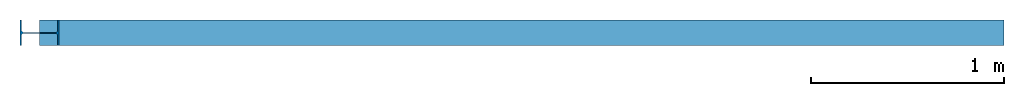
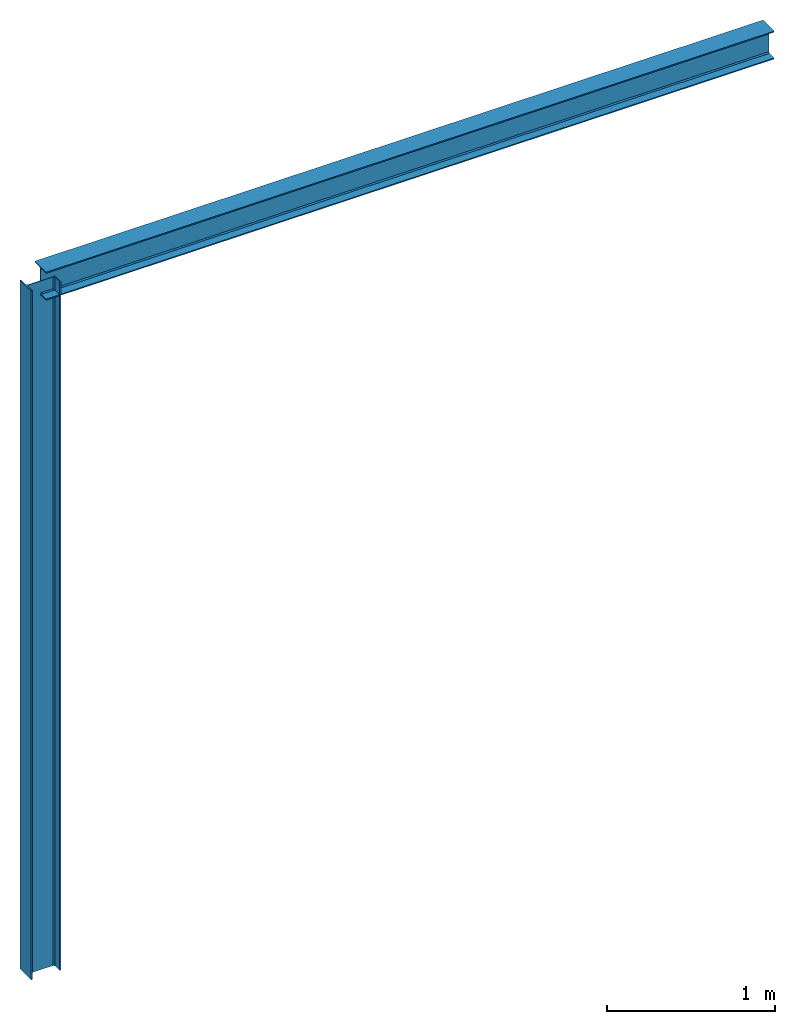
# One storey: 1 beam, 1 column.
"""IFC2X3 building model written with IfcOpenShell, lengths in millimetres."""

from ifc_helpers import new_model, si_unit, frame, origin_with_axes, place, context, project, spatial, polyline, outline, extrude, material, material_list, element, save


model = new_model("IFC2X3")

# Units and contexts
model_context = context("Model", 3, precision=1e-05, world=origin_with_axes())
ifc_project = project(units=[si_unit("PLANEANGLEUNIT", "RADIAN"), si_unit("MASSUNIT", "GRAM", prefix="KILO"), si_unit("FORCEUNIT", "NEWTON", prefix="KILO"), si_unit("LENGTHUNIT", "METRE", prefix="MILLI")], contexts=[model_context])

# Site, building, storey
site_placement = place(None, origin_with_axes())
site = spatial("IfcSite", under=ifc_project, at=site_placement, CompositionType="ELEMENT")
building_placement = place(None, origin_with_axes())
building = spatial("IfcBuilding", under=site, at=building_placement, Name="Building", CompositionType="ELEMENT")
storey_placement = place(None, origin_with_axes())
storey = spatial("IfcBuildingStorey", under=building, at=storey_placement, CompositionType="ELEMENT", Elevation=0.0)

# Column
ifc_material_1 = material(Name="S355")
ifc_material_2 = material(Name="steel")
ifc_material_list = material_list([ifc_material_1, ifc_material_2])
column_placement = place(building_placement, frame((5000.0, 0.0, 0.0), z_axis=(1.0, 0.0, 0.0), x_axis=(0.0, 0.0, 1.0)))
element("IfcColumn", 1, at=column_placement, inside=storey, material=ifc_material_list, Name="67", ObjectType="203X133X25UB", context=model_context, shape_type="SweptSolid", body=[
    extrude(outline(polyline([(-66.6, 101.6), (66.6, 101.6), (66.6, 93.8), (10.45, 93.8), (2.85, 86.2), (2.85, -86.2), (10.45, -93.8), (66.6, -93.8), (66.6, -101.6), (-66.6, -101.6), (-66.6, -93.8), (-10.45, -93.8), (-2.85, -86.2), (-2.85, 86.2), (-10.45, 93.8), (-66.6, 93.8), (-66.6, 101.6)])), frame((0.0, 0.0, 0.0), z_axis=(1.0, 0.0, 0.0), x_axis=(0.0, 1.0, 0.0)), (0.0, 0.0, 1.0), 5000.0),
])

# Beam
beam_placement = place(building_placement, frame((5000.0, 0.0, 5000.0), z_axis=(0.0, 0.0, 1.0), x_axis=(1.0, 0.0, 0.0)))
element("IfcBeam", 2, at=beam_placement, inside=storey, material=ifc_material_list, Name="51", ObjectType="203X133X25UB", context=model_context, shape_type="SweptSolid", body=[
    extrude(outline(polyline([(-66.6, 101.6), (66.6, 101.6), (66.6, 93.8), (10.45, 93.8), (2.85, 86.2), (2.85, -86.2), (10.45, -93.8), (66.6, -93.8), (66.6, -101.6), (-66.6, -101.6), (-66.6, -93.8), (-10.45, -93.8), (-2.85, -86.2), (-2.85, 86.2), (-10.45, 93.8), (-66.6, 93.8), (-66.6, 101.6)])), frame((0.0, 0.0, 0.0), z_axis=(1.0, 0.0, 0.0), x_axis=(0.0, 1.0, 0.0)), (0.0, 0.0, 1.0), 5000.0),
])

save(model, "model.ifc")
